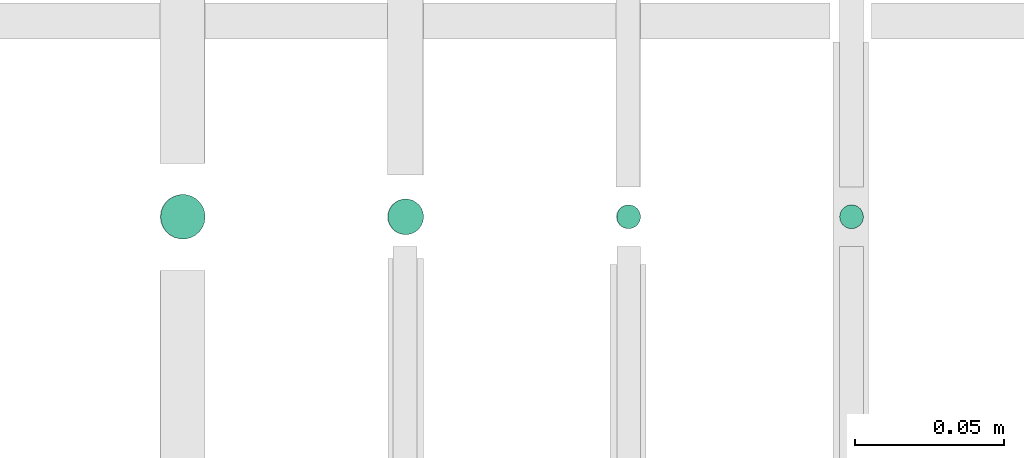
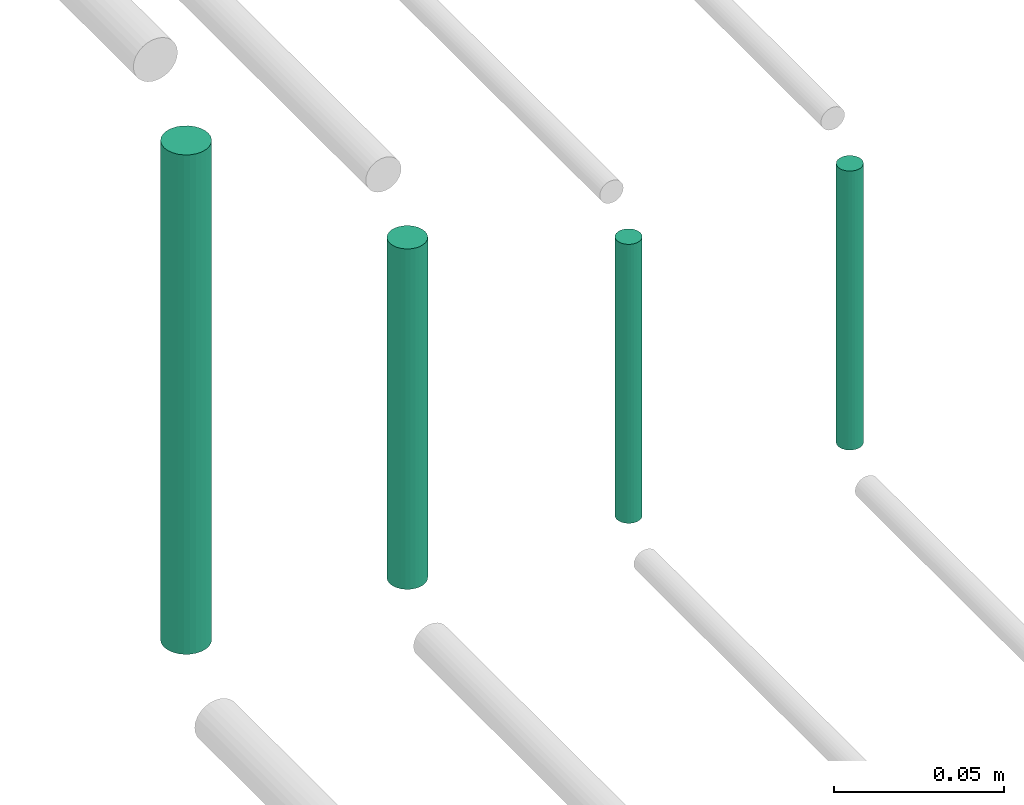
# One storey, part 131 of 331: 4 flow segments.
"""IFC2X3 building model written with IfcOpenShell, lengths in millimetres."""

import ifcopenshell
import ifcopenshell.guid

model = None  # the IFC model being written
_history = None  # IfcOwnerHistory: only IFC2X3 demands one
_inside = {}  # id of a spatial element -> (the spatial element, [elements in it])
_under = {}  # id of a project, library or spatial element -> (it, [spatial elements below it])
_declared = {}  # id of a project -> (the project, [libraries it declares])
_typed = {}  # id of a type object -> (the type object, [elements of that type])
_made_of = {}  # id of a material, layer set ... -> (it, [elements and type objects made of it])


def new_model(schema):
    """Start an empty IFC model of exactly this schema.

    Asked for "IFC4X3", IfcOpenShell would pick the latest addendum, in which some entities
    have other attributes; the version numbers below select the first issue.
    IFC2X3 requires an IfcOwnerHistory on every rooted entity: one is made here for all.
    """
    global model, _history
    if schema == "IFC4X3":
        model = ifcopenshell.file(schema_version=(4, 3, 0, 0))
    else:
        model = ifcopenshell.file(schema=schema)
    _inside.clear()
    _under.clear()
    _declared.clear()
    _typed.clear()
    _made_of.clear()
    _history = None
    if model.schema == "IFC2X3":
        org = make("IfcOrganization", Name="unknown")
        user = make(
            "IfcPersonAndOrganization",
            ThePerson=make("IfcPerson", FamilyName="unknown"),
            TheOrganization=org,
        )
        app = make(
            "IfcApplication",
            ApplicationDeveloper=org,
            Version="unknown",
            ApplicationFullName="unknown",
            ApplicationIdentifier="unknown",
        )
        _history = make(
            "IfcOwnerHistory",
            OwningUser=user,
            OwningApplication=app,
            ChangeAction="ADDED",
            CreationDate=0,
        )
    return model


def make(cls, **values):
    """One entity of the class cls with the attributes given. An attribute that is None is left unset."""
    return model.create_entity(
        cls, **{name: value for name, value in values.items() if value is not None}
    )


def entity(cls, *values):
    """Any entity or typed value of the class cls, its attributes in the order of the schema. None: left unset."""
    e = model.create_entity(cls)
    for i, value in enumerate(values):
        if value is not None:
            e[i] = value
    return e


def rooted(cls, **values):
    """An entity with a GlobalId (a new one), such as an element, a storey or a relation."""
    return make(cls, GlobalId=ifcopenshell.guid.new(), OwnerHistory=_history, **values)


def si_unit(unit_type, name, prefix=None):
    """IfcSIUnit, for example si_unit("LENGTHUNIT", "METRE", prefix="MILLI")."""
    return make("IfcSIUnit", UnitType=unit_type, Prefix=prefix, Name=name)


def converted_unit(unit_type, name, factor, base, dimensions=None, offset=None):
    """IfcConversionBasedUnit, such as the inch: factor (a typed value) times the base unit."""
    return make(
        "IfcConversionBasedUnit"
        if offset is None
        else "IfcConversionBasedUnitWithOffset",
        ConversionOffset=offset,
        Dimensions=None
        if dimensions is None
        else entity("IfcDimensionalExponents", *dimensions),
        UnitType=unit_type,
        Name=name,
        ConversionFactor=make(
            "IfcMeasureWithUnit", ValueComponent=factor, UnitComponent=base
        ),
    )


def derived_unit(unit_type, elements):
    """IfcDerivedUnit: a product of units, each with its exponent."""
    return make(
        "IfcDerivedUnit",
        Elements=[
            make("IfcDerivedUnitElement", Unit=unit, Exponent=power)
            for unit, power in elements
        ],
        UnitType=unit_type,
    )


def assignment(units):
    """IfcUnitAssignment: the units of a project."""
    return None if units is None else make("IfcUnitAssignment", Units=units)


def point(xyz):
    """IfcCartesianPoint."""
    return None if xyz is None else make("IfcCartesianPoint", Coordinates=xyz)


def direction(xyz):
    """IfcDirection."""
    return None if xyz is None else make("IfcDirection", DirectionRatios=xyz)


def frame(location, z_axis=None, x_axis=None):
    """IfcAxis2Placement3D, a coordinate frame: its origin and axes. An axis left out is left unset."""
    return make(
        "IfcAxis2Placement3D",
        Location=point(location),
        Axis=direction(z_axis),
        RefDirection=direction(x_axis),
    )


def frame_2d(location, x_axis=None):
    """IfcAxis2Placement2D, a coordinate frame in the plane: its origin and x axis."""
    return make(
        "IfcAxis2Placement2D", Location=point(location), RefDirection=direction(x_axis)
    )


def origin():
    """The frame at (0, 0, 0) with its axes left unset."""
    return frame((0.0, 0.0, 0.0))


def origin_2d_with_axis():
    """The frame at (0, 0) in the plane with the x axis (1, 0) written out."""
    return frame_2d((0.0, 0.0), x_axis=(1.0, 0.0))


def place(relative_to, where):
    """IfcLocalPlacement: puts the frame where relative to a parent placement (None: the world)."""
    return make(
        "IfcLocalPlacement", PlacementRelTo=relative_to, RelativePlacement=where
    )


def context(
    kind, dimensions, precision=None, world=None, true_north=None, identifier=None
):
    """IfcGeometricRepresentationContext, for example the 3D "Model" context."""
    return make(
        "IfcGeometricRepresentationContext",
        ContextIdentifier=identifier,
        ContextType=kind,
        CoordinateSpaceDimension=dimensions,
        Precision=precision,
        WorldCoordinateSystem=world,
        TrueNorth=true_north,
    )


def subcontext(parent, identifier, kind, view, scale=None):
    """IfcGeometricRepresentationSubContext, for example "Body" below "Model"."""
    return make(
        "IfcGeometricRepresentationSubContext",
        ContextIdentifier=identifier,
        ContextType=kind,
        ParentContext=parent,
        TargetScale=scale,
        TargetView=view,
    )


def project(units=None, contexts=None):
    """IfcProject with its units and contexts."""
    return rooted(
        "IfcProject",
        Name="project",
        RepresentationContexts=contexts,
        UnitsInContext=assignment(units),
    )


def spatial(cls, under=None, at=None, **own):
    """A site, building, storey or space (cls), placed at a placement, below another one or the project."""
    s = rooted(cls, ObjectPlacement=at, **own)
    if under is not None:
        _under.setdefault(under.id(), (under, []))[1].append(s)
    return s


def profile(cls, at=None, kind="AREA", **sizes):
    """A parametric profile (cls). Its sizes go by their IFC names, for example OverallWidth=200.0."""
    return make(cls, ProfileType=kind, Position=at, **sizes)


def circle(**sizes):
    """IfcCircleProfileDef."""
    return profile("IfcCircleProfileDef", **sizes)


def extrude(swept, where, along, depth):
    """IfcExtrudedAreaSolid: the profile swept, set in the frame where, extruded along a direction by depth."""
    return make(
        "IfcExtrudedAreaSolid",
        SweptArea=swept,
        Position=where,
        ExtrudedDirection=direction(along),
        Depth=depth,
    )


def shape(context_of_items, identifier, shape_type, items):
    """IfcShapeRepresentation: the items that make up one representation, for example the "Body"."""
    return make(
        "IfcShapeRepresentation",
        ContextOfItems=context_of_items,
        RepresentationIdentifier=identifier,
        RepresentationType=shape_type,
        Items=items,
    )


def made_of(thing, what):
    """Note that an element or type object is made of a material, layer set ...; save() writes the relation."""
    if what is not None:
        _made_of.setdefault(what.id(), (what, []))[1].append(thing)
    return thing


def type_object(cls, material=None, **own):
    """A type object (cls), such as IfcWallType, which elements share."""
    return made_of(rooted(cls, **own), material)


def element(
    cls,
    number,
    at=None,
    inside=None,
    cuts=None,
    type_object=None,
    material=None,
    context=None,
    identifier="Body",
    shape_type=None,
    held_by="IfcProductDefinitionShape",
    body=None,
    shapes=None,
    **own,
):
    """One element of the class cls, such as IfcWall. Its Tag is "e" and its number.

    at: its placement. inside: the storey or other place that contains it. cuts: it is an
    opening in that element (IfcRelVoidsElement). A single representation is given by context,
    identifier, shape_type and body (its items); several are given by shapes. held_by: the class
    of the entity that holds the representations. save() writes the other relations.
    """
    e = rooted(cls, Tag="e%d" % number, ObjectPlacement=at, **own)
    if body is not None:
        shapes = [shape(context, identifier, shape_type, body)]
    if shapes is not None:
        e.Representation = make(held_by, Representations=shapes)
    if inside is not None:
        _inside.setdefault(inside.id(), (inside, []))[1].append(e)
    if cuts is not None:
        rooted(
            "IfcRelVoidsElement", RelatingBuildingElement=cuts, RelatedOpeningElement=e
        )
    if type_object is not None:
        _typed.setdefault(type_object.id(), (type_object, []))[1].append(e)
    return made_of(e, material)


def aggregate(whole, parts):
    """IfcRelAggregates: a whole, such as a stair, and the parts it consists of."""
    return rooted("IfcRelAggregates", RelatingObject=whole, RelatedObjects=parts)


def save(model, path):
    """Write the relations noted so far, then the file.

    IfcRelAggregates (storeys below a building ...), IfcRelContainedInSpatialStructure (elements
    in a storey), IfcRelDefinesByType, IfcRelAssociatesMaterial and IfcRelDeclares: one each for
    every whole, place, type object, material and project.
    """
    for whole, parts in _under.values():
        aggregate(whole, parts)
    for where, things in _inside.values():
        rooted(
            "IfcRelContainedInSpatialStructure",
            RelatedElements=things,
            RelatingStructure=where,
        )
    for kind, things in _typed.values():
        rooted("IfcRelDefinesByType", RelatedObjects=things, RelatingType=kind)
    for what, things in _made_of.values():
        rooted("IfcRelAssociatesMaterial", RelatedObjects=things, RelatingMaterial=what)
    for by, libraries in _declared.values():
        rooted("IfcRelDeclares", RelatingContext=by, RelatedDefinitions=libraries)
    model.write(path)


model = new_model("IFC2X3")

# Units and contexts
model_context = context("Model", 3, precision=0.01, world=origin(), true_north=direction((6.12303176911189e-17, 1.0)))
body_context = subcontext(model_context, "Body", "Model", "MODEL_VIEW")
ifc_project = project(units=[si_unit("LENGTHUNIT", "METRE", prefix="MILLI"), si_unit("AREAUNIT", "SQUARE_METRE"), si_unit("VOLUMEUNIT", "CUBIC_METRE"), converted_unit("PLANEANGLEUNIT", "DEGREE", entity("IfcRatioMeasure", 0.0174532925199433), si_unit("PLANEANGLEUNIT", "RADIAN"), dimensions=[0, 0, 0, 0, 0, 0, 0]), si_unit("MASSUNIT", "GRAM", prefix="KILO"), derived_unit("MASSDENSITYUNIT", [(si_unit("MASSUNIT", "GRAM", prefix="KILO"), 1), (si_unit("LENGTHUNIT", "METRE"), -3)]), derived_unit("MOMENTOFINERTIAUNIT", [(si_unit("LENGTHUNIT", "METRE"), 4)]), si_unit("TIMEUNIT", "SECOND"), si_unit("FREQUENCYUNIT", "HERTZ"), si_unit("THERMODYNAMICTEMPERATUREUNIT", "DEGREE_CELSIUS"), derived_unit("THERMALTRANSMITTANCEUNIT", [(si_unit("MASSUNIT", "GRAM", prefix="KILO"), 1), (si_unit("THERMODYNAMICTEMPERATUREUNIT", "KELVIN"), -1), (si_unit("TIMEUNIT", "SECOND"), -3)]), derived_unit("VOLUMETRICFLOWRATEUNIT", [(si_unit("LENGTHUNIT", "METRE"), 3), (si_unit("TIMEUNIT", "SECOND"), -1)]), derived_unit("MASSFLOWRATEUNIT", [(si_unit("MASSUNIT", "GRAM", prefix="KILO"), 1), (si_unit("TIMEUNIT", "SECOND"), -1)]), derived_unit("ROTATIONALFREQUENCYUNIT", [(si_unit("TIMEUNIT", "SECOND"), -1)]), si_unit("ELECTRICCURRENTUNIT", "AMPERE"), si_unit("ELECTRICVOLTAGEUNIT", "VOLT"), si_unit("POWERUNIT", "WATT"), si_unit("FORCEUNIT", "NEWTON", prefix="KILO"), si_unit("ILLUMINANCEUNIT", "LUX"), si_unit("LUMINOUSFLUXUNIT", "LUMEN"), si_unit("LUMINOUSINTENSITYUNIT", "CANDELA"), derived_unit("USERDEFINED", [(si_unit("MASSUNIT", "GRAM", prefix="KILO"), -1), (si_unit("LENGTHUNIT", "METRE"), -2), (si_unit("TIMEUNIT", "SECOND"), 3), (si_unit("LUMINOUSFLUXUNIT", "LUMEN"), 1)]), derived_unit("LINEARVELOCITYUNIT", [(si_unit("LENGTHUNIT", "METRE"), 1), (si_unit("TIMEUNIT", "SECOND"), -1)]), si_unit("PRESSUREUNIT", "PASCAL"), derived_unit("USERDEFINED", [(si_unit("LENGTHUNIT", "METRE"), -2), (si_unit("MASSUNIT", "GRAM", prefix="KILO"), 1), (si_unit("TIMEUNIT", "SECOND"), -2)]), derived_unit("LINEARFORCEUNIT", [(si_unit("MASSUNIT", "GRAM", prefix="KILO"), 1), (si_unit("LENGTHUNIT", "METRE"), 1), (si_unit("TIMEUNIT", "SECOND"), -2), (si_unit("LENGTHUNIT", "METRE"), -1)]), derived_unit("PLANARFORCEUNIT", [(si_unit("MASSUNIT", "GRAM", prefix="KILO"), 1), (si_unit("LENGTHUNIT", "METRE"), 1), (si_unit("TIMEUNIT", "SECOND"), -2), (si_unit("LENGTHUNIT", "METRE"), -2)])], contexts=[model_context])

# Site, building, storey
site_placement = place(None, frame((0.0, -0.00077364408347762, 0.0)))
site = spatial("IfcSite", under=ifc_project, at=site_placement, CompositionType="ELEMENT")
building_placement = place(site_placement, origin())
building = spatial("IfcBuilding", under=site, at=building_placement, CompositionType="ELEMENT")
storey_placement = place(building_placement, origin())
storey = spatial("IfcBuildingStorey", under=building, at=storey_placement, CompositionType="ELEMENT", Elevation=0.0)

# Flow segments
pipe_segment_type = type_object("IfcPipeSegmentType", PredefinedType="NOTDEFINED")
flow_segment_1_placement = place(storey_placement, frame((20765.733655358, 8084.55353441894, 18460.0)))
element("IfcFlowSegment", 1, at=flow_segment_1_placement, inside=storey, type_object=pipe_segment_type, context=body_context, shape_type="SweptSolid", body=[
    extrude(circle(Radius=4.0, at=origin_2d_with_axis()), frame((5.59527223591499, 5.59527223591607, 0.0)), (0.0, 0.0, 1.0), 99.9999999999903),
])
flow_segment_2_placement = place(storey_placement, frame((20688.733655358, 8082.55353441894, 18464.0)))
element("IfcFlowSegment", 2, at=flow_segment_2_placement, inside=storey, type_object=pipe_segment_type, context=body_context, shape_type="SweptSolid", body=[
    extrude(circle(Radius=6.0, at=frame_2d((0.0, 1.08286712929839e-12), x_axis=(1.0, 0.0))), frame((7.59527223591454, 7.59527223591454, 0.0)), (0.0, 0.0, 1.0), 121.999999999977),
])
flow_segment_3_placement = place(storey_placement, frame((20612.233655358, 8081.05353441894, 18468.0)))
element("IfcFlowSegment", 3, at=flow_segment_3_placement, inside=storey, type_object=pipe_segment_type, context=body_context, shape_type="SweptSolid", body=[
    extrude(circle(Radius=7.5, at=origin_2d_with_axis()), frame((9.09527223591419, 9.09527223591636, 0.0)), (0.0, 0.0, 1.0), 179.000000000009),
])
flow_segment_4_placement = place(building_placement, frame((20840.733655358, 8084.55353441894, 18460.0)))
element("IfcFlowSegment", 4, at=flow_segment_4_placement, inside=storey, type_object=pipe_segment_type, context=body_context, shape_type="SweptSolid", body=[
    extrude(circle(Radius=4.0, at=origin_2d_with_axis()), frame((5.59527223591499, 5.59527223591607, 0.0)), (0.0, 0.0, 1.0), 100.000000000014),
])

save(model, "model.ifc")
